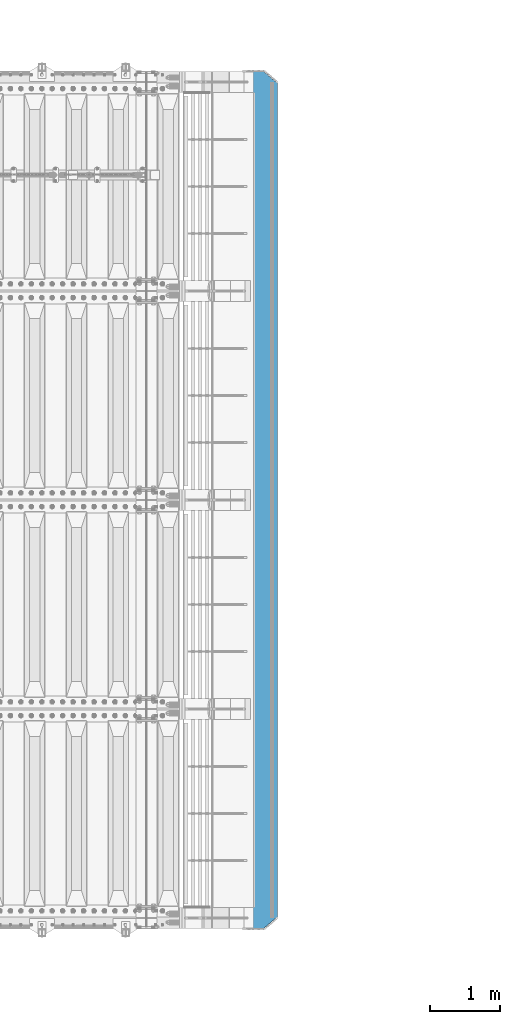
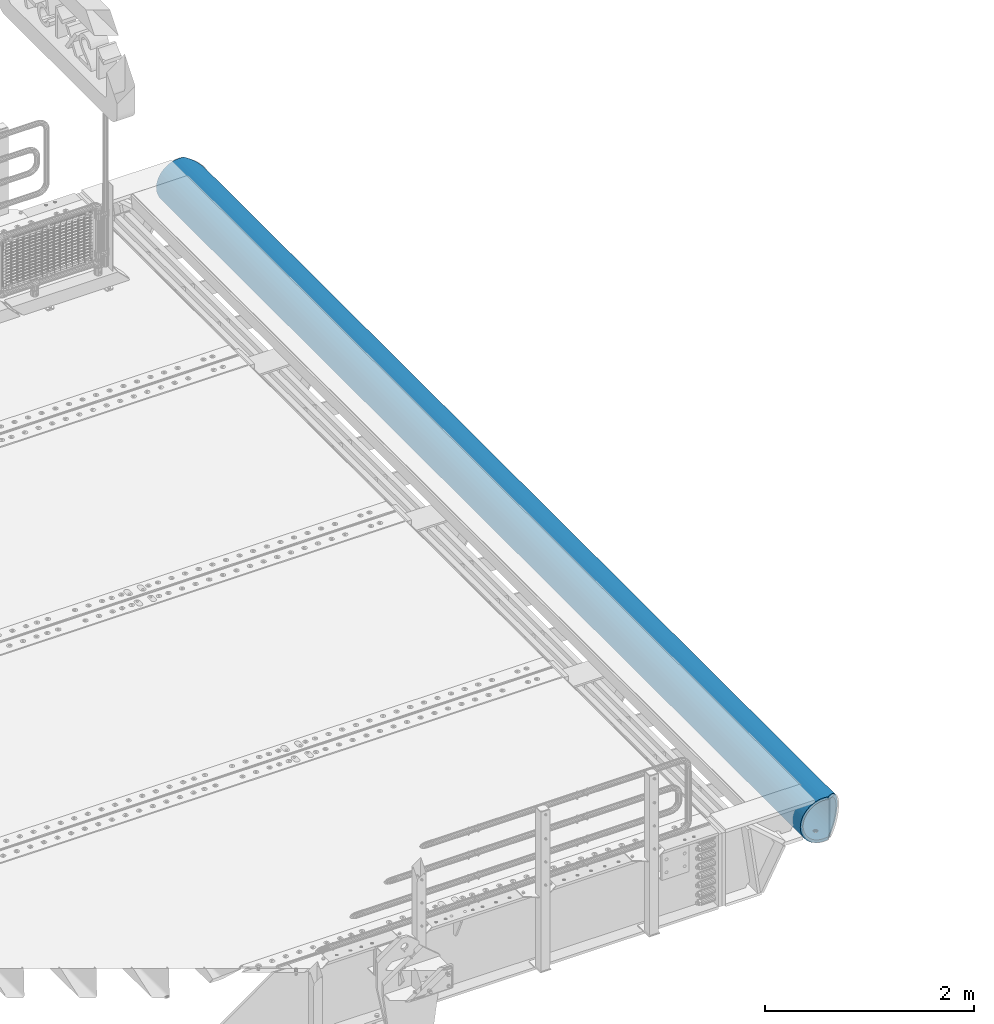
# One storey, part 129 of 240: 1 beam.
"""IFC2X3 building model written with IfcOpenShell, lengths in millimetres."""

from ifc_helpers import new_model, si_unit, frame, origin_with_axes, place, context, subcontext, project, spatial, faceted_brep, material, type_object, element, save


model = new_model("IFC2X3")

# Units and contexts
model_context = context("Model", 3, precision=1e-05, world=origin_with_axes())
body_context = subcontext(model_context, "Body", "Model", "MODEL_VIEW")
ifc_project = project(units=[si_unit("LENGTHUNIT", "METRE", prefix="MILLI"), si_unit("AREAUNIT", "SQUARE_METRE"), si_unit("VOLUMEUNIT", "CUBIC_METRE"), si_unit("MASSUNIT", "GRAM", prefix="KILO"), si_unit("TIMEUNIT", "SECOND"), si_unit("PLANEANGLEUNIT", "RADIAN"), si_unit("SOLIDANGLEUNIT", "STERADIAN"), si_unit("THERMODYNAMICTEMPERATUREUNIT", "DEGREE_CELSIUS"), si_unit("LUMINOUSINTENSITYUNIT", "LUMEN")], contexts=[model_context])

# Site, building, storey
site_placement = place(None, origin_with_axes())
site = spatial("IfcSite", under=ifc_project, at=site_placement, CompositionType="ELEMENT")
building_placement = place(site_placement, origin_with_axes())
building = spatial("IfcBuilding", under=site, at=building_placement, Name="Standard", CompositionType="ELEMENT")
storey_placement = place(building_placement, origin_with_axes())
storey = spatial("IfcBuildingStorey", under=building, at=storey_placement, Name="Undefined", CompositionType="ELEMENT", Elevation=0.0)

# Beam
ifc_material = material(Name="STEEL/S355N")
beam_type = type_object("IfcBeamType", PredefinedType="NOTDEFINED")
beam_placement = place(storey_placement, frame((57632.9988298906, 36150.0, -254.000000000001), z_axis=(0.0, 0.0, 1.0), x_axis=(0.0, -1.0, 0.0)))
element("IfcBeam", 1, at=beam_placement, inside=storey, type_object=beam_type, material=ifc_material, context=body_context, shape_type="Brep", body=[
    faceted_brep([(4626.90301168722, -9.56338969324133, -221.247344908115), (4626.90301168722, -9.56338969324133, -253.247344908114), (4625.0, 0.0, -254.0), (4625.0, 0.0, -222.0), (4632.32233047034, -17.6739734137809, -220.609028125964), (4632.32233047034, -17.6739734137809, -252.609028125964), (4640.43291419087, -23.0932921968997, -220.182518487905), (4640.43291419087, -23.0932921968997, -252.182518487906), (4650.0, -24.9963038841161, -220.032748220014), (4650.0, -24.9963038841161, -252.032748220015), (4659.56708580913, -23.0932921968997, -220.182518487905), (4659.56708580913, -23.0932921968997, -252.182518487906), (4667.67766952966, -17.6739734137809, -220.609028125964), (4667.67766952966, -17.6739734137809, -252.609028125964), (4673.09698831278, -9.56338969324133, -221.247344908115), (4673.09698831278, -9.56338969324133, -253.247344908114), (4675.0, 0.0, -222.0), (4675.0, 0.0, -254.0), (4673.09698831278, 9.57078192500921, -221.246763126854), (4673.09698831278, 9.57078192500921, -253.246763126854), (4667.67766952966, 17.6813656455488, -220.608446344703), (4667.67766952966, 17.6813656455488, -252.608446344703), (4659.56708580913, 23.1006844286676, -220.181936706645), (4659.56708580913, 23.1006844286676, -252.181936706646), (4650.0, 25.0036961158839, -220.032166438754), (4650.0, 25.0036961158839, -252.032166438755), (4640.43291419087, 23.1006844286676, -220.181936706645), (4640.43291419087, 23.1006844286676, -252.181936706646), (4632.32233047034, 17.6813656455488, -220.608446344703), (4632.32233047034, 17.6813656455488, -252.608446344703), (4626.90301168722, 9.57078192500921, -221.246763126854), (4626.90301168722, 9.57078192500921, -253.246763126854), (3126.90301168722, -9.56708580912527, -221.247054017484), (3126.90301168722, -9.56708580912527, -253.247054017484), (3125.0, 0.0, -254.0), (3125.0, 0.0, -222.0), (3132.32233047034, -17.6776695296649, -220.608737235334), (3132.32233047034, -17.6776695296649, -252.608737235333), (3140.43291419087, -23.0969883127837, -220.182227597276), (3140.43291419087, -23.0969883127837, -252.182227597276), (3150.0, -25.0, -220.032457329384), (3150.0, -25.0, -252.032457329385), (3159.56708580913, -23.0969883127837, -220.182227597276), (3159.56708580913, -23.0969883127837, -252.182227597276), (3167.67766952966, -17.6776695296649, -220.608737235334), (3167.67766952966, -17.6776695296649, -252.608737235333), (3173.09698831278, -9.56708580912527, -221.247054017484), (3173.09698831278, -9.56708580912527, -253.247054017484), (3175.0, 0.0, -222.0), (3175.0, 0.0, -254.0), (3173.09698831278, 9.56708580912527, -221.247054017484), (3173.09698831278, 9.56708580912527, -253.247054017485), (3167.67766952966, 17.6776695296649, -220.608737235333), (3167.67766952966, 17.6776695296649, -252.608737235334), (3159.56708580913, 23.0969883127837, -220.182227597276), (3159.56708580913, 23.0969883127837, -252.182227597275), (3150.0, 25.0, -220.032457329385), (3150.0, 25.0, -252.032457329385), (3140.43291419087, 23.0969883127837, -220.182227597276), (3140.43291419087, 23.0969883127837, -252.182227597275), (3132.32233047034, 17.6776695296649, -220.608737235333), (3132.32233047034, 17.6776695296649, -252.608737235334), (3126.90301168722, 9.56708580912527, -221.247054017484), (3126.90301168722, 9.56708580912527, -253.247054017485), (1626.90301168722, -9.56708580912527, -221.247054017486), (1626.90301168722, -9.56708580912527, -253.247054017484), (1625.0, 0.0, -254.0), (1625.0, 0.0, -222.0), (1632.32233047034, -17.6776695296649, -220.608737235335), (1632.32233047034, -17.6776695296649, -252.608737235335), (1640.43291419087, -23.0969883127837, -220.182227597277), (1640.43291419087, -23.0969883127837, -252.182227597276), (1650.0, -25.0, -220.032457329385), (1650.0, -25.0, -252.032457329385), (1659.56708580913, -23.0969883127837, -220.182227597277), (1659.56708580913, -23.0969883127837, -252.182227597276), (1667.67766952966, -17.6776695296649, -220.608737235335), (1667.67766952966, -17.6776695296649, -252.608737235335), (1673.09698831278, -9.56708580912527, -221.247054017486), (1673.09698831278, -9.56708580912527, -253.247054017484), (1675.0, 0.0, -222.0), (1675.0, 0.0, -254.0), (1673.09698831278, 9.56708580912527, -221.247054017484), (1673.09698831278, 9.56708580912527, -253.247054017484), (1667.67766952966, 17.6776695296649, -220.608737235334), (1667.67766952966, 17.6776695296649, -252.608737235334), (1659.56708580913, 23.0969883127837, -220.182227597276), (1659.56708580913, 23.0969883127837, -252.182227597276), (1650.0, 25.0, -220.032457329384), (1650.0, 25.0, -252.032457329384), (1640.43291419087, 23.0969883127837, -220.182227597276), (1640.43291419087, 23.0969883127837, -252.182227597276), (1632.32233047034, 17.6776695296649, -220.608737235334), (1632.32233047034, 17.6776695296649, -252.608737235334), (1626.90301168722, 9.56708580912527, -221.247054017484), (1626.90301168722, 9.56708580912527, -253.247054017484), (126.903011687216, -9.56708580912527, -221.247054017485), (126.903011687216, -9.56708580912527, -253.247054017485), (125.0, 0.0, -254.0), (125.0, 0.0, -222.0), (132.322330470335, -17.6776695296649, -220.608737235334), (132.322330470335, -17.6776695296649, -252.608737235334), (140.432914190875, -23.0969883127837, -220.182227597276), (140.432914190875, -23.0969883127837, -252.182227597276), (150.0, -25.0, -220.032457329384), (150.0, -25.0, -252.032457329385), (159.567085809125, -23.0969883127837, -220.182227597276), (159.567085809125, -23.0969883127837, -252.182227597276), (167.677669529665, -17.6776695296649, -220.608737235334), (167.677669529665, -17.6776695296649, -252.608737235334), (173.096988312784, -9.56708580912527, -221.247054017485), (173.096988312784, -9.56708580912527, -253.247054017485), (175.0, 0.0, -222.0), (175.0, 0.0, -254.0), (173.096988312784, 9.56708580912527, -221.247054017484), (173.096988312784, 9.56708580912527, -253.247054017484), (167.677669529665, 17.6776695296649, -220.608737235333), (167.677669529665, 17.6776695296649, -252.608737235334), (159.567085809125, 23.0969883127837, -220.182227597276), (159.567085809125, 23.0969883127837, -252.182227597276), (150.0, 25.0, -220.032457329384), (150.0, 25.0, -252.032457329385), (140.432914190875, 23.0969883127837, -220.182227597276), (140.432914190875, 23.0969883127837, -252.182227597276), (132.322330470335, 17.6776695296649, -220.608737235333), (132.322330470335, 17.6776695296649, -252.608737235334), (126.903011687216, 9.56708580912527, -221.247054017484), (126.903011687216, 9.56708580912527, -253.247054017484), (0.0, -34.7284512389306, -219.266811612121), (0.0, -68.6017727512371, -211.134546617524), (12300.0, -68.6017727512371, -211.134546617524), (12300.0, -34.7284512389306, -219.266811612121), (0.0, -100.785890942178, -197.803448369818), (12300.0, -100.785890942178, -197.803448369818), (0.0, -130.488326008926, -179.601772751238), (12300.0, -130.488326008926, -179.601772751238), (0.0, -156.977705423415, -156.977705423414), (12300.0, -156.977705423415, -156.977705423414), (0.0, -179.601772751237, -130.488326008929), (12300.0, -179.601772751237, -130.488326008929), (0.0, -197.803448369821, -100.785890942179), (12300.0, -197.803448369821, -100.785890942179), (0.0, -211.134546617526, -68.6017727512383), (12300.0, -211.134546617526, -68.6017727512383), (0.0, -219.26681161212, -34.7284512389313), (12300.0, -219.26681161212, -34.7284512389313), (0.0, -222.0, 0.0), (12300.0, -222.0, 0.0), (0.0, -219.26681161212, 34.7284512389313), (12300.0, -219.26681161212, 34.7284512389313), (0.0, -211.134546617526, 68.6017727512384), (12300.0, -211.134546617526, 68.6017727512384), (0.0, -197.803448369821, 100.785890942179), (12300.0, -197.803448369821, 100.785890942179), (0.0, -179.601772751237, 130.488326008929), (12300.0, -179.601772751237, 130.488326008929), (0.0, -156.977705423415, 156.977705423414), (12300.0, -156.977705423415, 156.977705423414), (0.0, -130.488326008926, 179.601772751238), (12300.0, -130.488326008926, 179.601772751238), (0.0, -100.785890942178, 197.803448369818), (12300.0, -100.785890942178, 197.803448369818), (0.0, -68.6017727512371, 211.134546617524), (12300.0, -68.6017727512371, 211.134546617524), (0.0, -34.7284512389306, 219.266811612121), (12300.0, -34.7284512389306, 219.266811612121), (0.0, 0.0, 222.0), (12300.0, 0.0, 222.0), (0.0, 34.7284512389306, 219.266811612121), (12300.0, 34.7284512389306, 219.266811612121), (12287.5916350976, 68.6017727512371, 211.134546617524), (12300.0, 54.0036961158839, 214.639234741096), (0.0, 54.0, 214.640122100011), (12.4115067427192, 68.6017727512371, 211.134546617524), (12260.2351351591, 100.785890942178, 197.803448369818), (39.7680069938215, 100.785890942178, 197.803448369818), (12234.9880658358, 130.488326008926, 179.601772751238), (65.0150766056468, 130.488326008926, 179.601772751238), (12212.4720937646, 156.977705423415, 156.977705423414), (87.5310489341209, 156.977705423415, 156.977705423414), (12193.2416369042, 179.601772751237, 130.488326008929), (106.761506014307, 179.601772751237, 130.488326008929), (12177.7702129247, 197.803448369821, 100.785890942179), (122.232930170649, 197.803448369821, 100.785890942179), (12166.4387796311, 211.134546617526, 68.6017727512383), (133.564363593716, 211.134546617526, 68.6017727512383), (12159.5263545181, 219.26681161212, 34.7284512389312), (140.476788785745, 219.26681161212, 34.7284512389312), (12157.2031444329, 222.0, -2.8421709430404e-14), (142.799998897506, 222.0, -2.8421709430404e-14), (12159.5263545181, 219.26681161212, -34.7284512389313), (140.476788785745, 219.26681161212, -34.7284512389313), (12166.4387796311, 211.134546617526, -68.6017727512383), (133.564363593716, 211.134546617526, -68.6017727512383), (12177.7702129247, 197.803448369821, -100.785890942179), (122.232930170649, 197.803448369821, -100.785890942179), (12193.2416369042, 179.601772751237, -130.488326008929), (106.761506014307, 179.601772751237, -130.488326008929), (12212.4720937646, 156.977705423415, -156.977705423414), (87.5310489341209, 156.977705423415, -156.977705423414), (12234.9880658358, 130.488326008926, -179.601772751238), (65.0150766056468, 130.488326008926, -179.601772751238), (12260.2351351591, 100.785890942178, -197.803448369818), (39.7680069938215, 100.785890942178, -197.803448369818), (12287.5916350976, 68.6017727512371, -211.134546617524), (12.4115067427192, 68.6017727512371, -211.134546617524), (0.0, 34.7284512389306, -219.266811612121), (12300.0, 34.7284512389306, -219.266811612121), (12300.0, 54.0036961158839, -214.639234741096), (0.0, 54.0, -214.640122100011), (12140.5700428833, 241.568355138967, -78.4903165712366), (12153.5348359309, 226.315657143845, -115.313586933845), (146.468307441457, 226.315657143845, -115.313586933845), (159.433100637223, 241.568355138967, -78.4903165712366), (12171.2363750786, 205.490316571239, -149.297454082288), (128.766768091402, 205.490316571239, -149.297454082288), (12193.2387896847, 179.605122421381, -179.605122421383), (106.764353233899, 179.605122421381, -179.605122421383), (12219.0003072796, 149.297454082291, -205.490316571237), (81.0028353445668, 149.297454082291, -205.490316571237), (12247.8865938026, 115.313586933844, -226.315657143845), (52.116548491409, 115.313586933844, -226.315657143845), (12279.1863730115, 78.4903165712385, -241.568355138969), (20.8167689248367, 78.4903165712385, -241.568355138969), (12300.0, 54.0036961158839, -247.447072591956), (12300.0, 39.7343541202208, -250.872838511165), (0.0, 39.7343541202208, -250.872838511165), (0.0, 54.0, -247.447959950871), (0.0, 0.0, -222.0), (0.0, 0.0, -254.0), (0.0, -39.7343541202208, -250.872838511165), (0.0, -78.4903165712385, -241.568355138969), (0.0, -115.313586933844, -226.315657143845), (0.0, -149.297454082291, -205.490316571237), (0.0, -179.605122421381, -179.605122421383), (0.0, -205.490316571239, -149.297454082288), (0.0, -226.315657143845, -115.313586933845), (0.0, -241.568355138967, -78.4903165712367), (0.0, -250.872838511168, -39.7343541202187), (0.0, -254.0, 0.0), (0.0, -250.872838511168, 39.7343541202187), (0.0, -241.568355138967, 78.4903165712366), (0.0, -226.315657143845, 115.313586933845), (0.0, -205.490316571239, 149.297454082288), (0.0, -179.605122421381, 179.605122421383), (0.0, -149.297454082291, 205.490316571237), (0.0, -115.313586933844, 226.315657143845), (0.0, -78.4903165712385, 241.568355138969), (0.0, -39.7343541202208, 250.872838511165), (0.0, 0.0, 254.0), (0.0, 39.7343541202208, 250.872838511165), (0.0, 54.0, 247.447959950871), (12300.0, -39.7343541202208, -250.872838511165), (12300.0, -78.4903165712385, -241.568355138969), (12300.0, -115.313586933844, -226.315657143845), (12300.0, -149.297454082291, -205.490316571237), (12300.0, -179.605122421381, -179.605122421383), (12300.0, -205.490316571239, -149.297454082288), (12300.0, -226.315657143845, -115.313586933845), (12300.0, -241.568355138967, -78.4903165712367), (12300.0, -250.872838511168, -39.7343541202187), (12300.0, -254.0, 0.0), (12300.0, -250.872838511168, 39.7343541202187), (12300.0, -241.568355138967, 78.4903165712366), (12300.0, -226.315657143845, 115.313586933845), (12300.0, -205.490316571239, 149.297454082288), (12300.0, -179.605122421381, 179.605122421383), (12300.0, -149.297454082291, 205.490316571237), (12300.0, -115.313586933844, 226.315657143845), (12300.0, -78.4903165712385, 241.568355138969), (12300.0, -39.7343541202208, 250.872838511165), (12300.0, 0.0, 254.0), (12300.0, 39.7343541202208, 250.872838511165), (12300.0, 54.0036961158839, 247.447072591956), (12279.1863730115, 78.4903165712385, 241.568355138969), (20.8167689248367, 78.4903165712385, 241.568355138969), (12247.8865938026, 115.313586933844, 226.315657143845), (52.116548491409, 115.313586933844, 226.315657143845), (12219.0003072796, 149.297454082291, 205.490316571237), (81.0028353445668, 149.297454082291, 205.490316571237), (12193.2387896847, 179.605122421381, 179.605122421383), (106.764353233899, 179.605122421381, 179.605122421383), (12171.2363750786, 205.490316571239, 149.297454082288), (128.766768091402, 205.490316571239, 149.297454082288), (12153.5348359309, 226.315657143845, 115.313586933845), (146.468307441457, 226.315657143845, 115.313586933845), (12140.5700428833, 241.568355138967, 78.4903165712367), (159.433100637223, 241.568355138967, 78.4903165712367), (12129.9999998327, 254.003700142486, 0.0), (12132.6612321683, 250.872838511168, -39.7343541202186), (167.341911442534, 250.872838511168, -39.7343541202186), (170.000001295222, 254.000003067893, 5.6843418860808e-14), (12132.6612321683, 250.872838511168, 39.7343541202187), (167.341911442534, 250.872838511168, 39.7343541202187), (12300.0, 0.0, -254.0), (12300.0, 0.0, -222.0), (12126.9030116872, -9.56338969324861, -221.247344908115), (12126.9030116872, -9.56338969324861, -253.247344908113), (12125.0, 0.0, -254.0), (12125.0, 0.0, -222.0), (12132.3223304703, -17.6739734137882, -220.609028125964), (12132.3223304703, -17.6739734137882, -252.609028125963), (12140.4329141909, -23.093292196907, -220.182518487906), (12140.4329141909, -23.093292196907, -252.182518487905), (12150.0, -24.9963038841233, -220.032748220015), (12150.0, -24.9963038841233, -252.032748220014), (12159.5670858091, -23.093292196907, -220.182518487906), (12159.5670858091, -23.093292196907, -252.182518487905), (12167.6776695297, -17.6739734137882, -220.609028125964), (12167.6776695297, -17.6739734137882, -252.609028125963), (12173.0969883128, -9.56338969324861, -221.247344908115), (12173.0969883128, -9.56338969324861, -253.247344908113), (12175.0, 0.0, -222.0), (12175.0, 0.0, -254.0), (12173.0969883128, 9.57078192500194, -221.246763126854), (12173.0969883128, 9.57078192500194, -253.246763126856), (12167.6776695297, 17.6813656455415, -220.608446344704), (12167.6776695297, 17.6813656455415, -252.608446344706), (12159.5670858091, 23.1006844286603, -220.181936706646), (12159.5670858091, 23.1006844286603, -252.181936706648), (12150.0, 25.0036961158767, -220.032166438754), (12150.0, 25.0036961158767, -252.032166438757), (12140.4329141909, 23.1006844286603, -220.181936706646), (12140.4329141909, 23.1006844286603, -252.181936706648), (12132.3223304703, 17.6813656455415, -220.608446344704), (12132.3223304703, 17.6813656455415, -252.608446344706), (12126.9030116872, 9.57078192500194, -221.246763126854), (12126.9030116872, 9.57078192500194, -253.246763126856), (10626.9030116872, -9.56338969324861, -221.247344908114), (10626.9030116872, -9.56338969324861, -253.247344908111), (10625.0, 0.0, -254.0), (10625.0, 0.0, -222.0), (10632.3223304703, -17.6739734137882, -220.609028125963), (10632.3223304703, -17.6739734137882, -252.609028125961), (10640.4329141909, -23.093292196907, -220.182518487905), (10640.4329141909, -23.093292196907, -252.182518487903), (10650.0, -24.9963038841233, -220.032748220014), (10650.0, -24.9963038841233, -252.032748220012), (10659.5670858091, -23.093292196907, -220.182518487905), (10659.5670858091, -23.093292196907, -252.182518487903), (10667.6776695297, -17.6739734137882, -220.609028125963), (10667.6776695297, -17.6739734137882, -252.609028125961), (10673.0969883128, -9.56338969324861, -221.247344908114), (10673.0969883128, -9.56338969324861, -253.247344908111), (10675.0, 0.0, -222.0), (10675.0, 0.0, -254.0), (10673.0969883128, 9.57078192500194, -221.246763126852), (10673.0969883128, 9.57078192500194, -253.246763126853), (10667.6776695297, 17.6813656455415, -220.608446344702), (10667.6776695297, 17.6813656455415, -252.608446344703), (10659.5670858091, 23.1006844286603, -220.181936706644), (10659.5670858091, 23.1006844286603, -252.181936706645), (10650.0, 25.0036961158767, -220.032166438753), (10650.0, 25.0036961158767, -252.032166438754), (10640.4329141909, 23.1006844286603, -220.181936706644), (10640.4329141909, 23.1006844286603, -252.181936706645), (10632.3223304703, 17.6813656455415, -220.608446344702), (10632.3223304703, 17.6813656455415, -252.608446344703), (10626.9030116872, 9.57078192500194, -221.246763126852), (10626.9030116872, 9.57078192500194, -253.246763126853), (9132.32233047034, 17.6813656455415, -252.608446344704), (9126.90301168722, 9.57078192500194, -253.246763126854), (9125.0, 0.0, -254.0), (7675.0, 0.0, -254.0), (7673.09698831278, 9.57078192500194, -253.246763126854), (7667.67766952966, 17.6813656455415, -252.608446344704), (7659.56708580913, 23.1006844286603, -252.181936706646), (7650.0, 25.0036961158767, -252.032166438755), (7640.43291419087, 23.1006844286603, -252.181936706646), (7632.32233047034, 17.6813656455415, -252.608446344704), (7626.90301168722, 9.57078192500194, -253.246763126854), (7625.0, 0.0, -254.0), (6175.0, 0.0, -254.0), (6173.09698831278, 9.57078192500194, -253.246763126855), (6167.67766952966, 17.6813656455415, -252.608446344705), (6159.56708580913, 23.1006844286603, -252.181936706647), (6150.0, 25.0036961158767, -252.032166438756), (6140.43291419087, 23.1006844286603, -252.181936706647), (6132.32233047034, 17.6813656455415, -252.608446344705), (6126.90301168722, 9.57078192500194, -253.246763126855), (6125.0, 0.0, -254.0), (9175.0, 0.0, -254.0), (9173.09698831278, 9.57078192500194, -253.246763126854), (9167.67766952966, 17.6813656455415, -252.608446344704), (9159.56708580913, 23.1006844286603, -252.181936706646), (9150.0, 25.0036961158767, -252.032166438755), (9140.43291419087, 23.1006844286603, -252.181936706646), (7667.67766952966, 17.6813656455415, -220.608446344702), (7673.09698831278, 9.57078192500194, -221.246763126853), (7659.56708580913, 23.1006844286603, -220.181936706645), (7650.0, 25.0036961158767, -220.032166438754), (7640.43291419087, 23.1006844286603, -220.181936706645), (7632.32233047034, 17.6813656455415, -220.608446344702), (7626.90301168722, 9.57078192500194, -221.246763126853), (7625.0, 0.0, -222.0), (7626.90301168722, -9.56338969324861, -221.247344908116), (7626.90301168722, -9.56338969324861, -253.247344908112), (7632.32233047034, -17.6739734137882, -220.609028125965), (7632.32233047034, -17.6739734137882, -252.609028125961), (7640.43291419087, -23.093292196907, -220.182518487907), (7640.43291419087, -23.093292196907, -252.182518487903), (7650.0, -24.9963038841233, -220.032748220015), (7650.0, -24.9963038841233, -252.032748220012), (7659.56708580913, -23.093292196907, -220.182518487907), (7659.56708580913, -23.093292196907, -252.182518487903), (7667.67766952966, -17.6739734137882, -220.609028125965), (7667.67766952966, -17.6739734137882, -252.609028125961), (7673.09698831278, -9.56338969324861, -221.247344908116), (7673.09698831278, -9.56338969324861, -253.247344908112), (7675.0, 0.0, -222.0), (9167.67766952966, 17.6813656455415, -220.608446344703), (9173.09698831278, 9.57078192500194, -221.246763126854), (9175.0, 0.0, -222.0), (6125.0, 0.0, -222.0), (6126.90301168722, 9.57078192500194, -221.246763126856), (6132.32233047034, 17.6813656455415, -220.608446344706), (6140.43291419087, 23.1006844286603, -220.181936706647), (6150.0, 25.0036961158767, -220.032166438755), (6159.56708580913, 23.1006844286603, -220.181936706647), (6167.67766952966, 17.6813656455415, -220.608446344706), (6173.09698831278, 9.57078192500194, -221.246763126856), (6175.0, 0.0, -222.0), (9125.0, 0.0, -222.0), (9126.90301168722, 9.57078192500194, -221.246763126854), (9132.32233047034, 17.6813656455415, -220.608446344703), (9140.43291419087, 23.1006844286603, -220.181936706645), (9150.0, 25.0036961158767, -220.032166438754), (9159.56708580913, 23.1006844286603, -220.181936706645), (6173.09698831278, -9.56338969324861, -221.247344908115), (6167.67766952966, -17.6739734137882, -220.609028125964), (6159.56708580913, -23.093292196907, -220.182518487906), (6150.0, -24.9963038841233, -220.032748220015), (6140.43291419087, -23.093292196907, -220.182518487906), (6132.32233047034, -17.6739734137882, -220.609028125964), (6126.90301168722, -9.56338969324861, -221.247344908115), (9173.09698831278, -9.56338969324861, -221.247344908112), (9167.67766952966, -17.6739734137882, -220.609028125962), (9159.56708580913, -23.093292196907, -220.182518487903), (9150.0, -24.9963038841233, -220.032748220012), (9140.43291419087, -23.093292196907, -220.182518487903), (9132.32233047034, -17.6739734137882, -220.609028125962), (9126.90301168722, -9.56338969324861, -221.247344908112), (9132.32233047034, -17.6739734137882, -252.609028125962), (9126.90301168722, -9.56338969324861, -253.247344908113), (9140.43291419087, -23.093292196907, -252.182518487905), (9150.0, -24.9963038841233, -252.032748220014), (9159.56708580913, -23.093292196907, -252.182518487905), (9167.67766952966, -17.6739734137882, -252.609028125962), (9173.09698831278, -9.56338969324861, -253.247344908113), (6126.90301168722, -9.56338969324861, -253.247344908114), (6132.32233047034, -17.6739734137882, -252.609028125964), (6140.43291419087, -23.093292196907, -252.182518487905), (6150.0, -24.9963038841233, -252.032748220014), (6159.56708580913, -23.093292196907, -252.182518487905), (6167.67766952966, -17.6739734137882, -252.609028125964), (6173.09698831278, -9.56338969324861, -253.247344908114)], [[[0, 1, 2, 3]], [[4, 5, 1, 0]], [[6, 7, 5, 4]], [[8, 9, 7, 6]], [[10, 11, 9, 8]], [[12, 13, 11, 10]], [[14, 15, 13, 12]], [[16, 17, 15, 14]], [[18, 19, 17, 16]], [[20, 21, 19, 18]], [[22, 23, 21, 20]], [[24, 25, 23, 22]], [[26, 27, 25, 24]], [[28, 29, 27, 26]], [[30, 31, 29, 28]], [[3, 2, 31, 30]], [[32, 33, 34, 35]], [[36, 37, 33, 32]], [[38, 39, 37, 36]], [[40, 41, 39, 38]], [[42, 43, 41, 40]], [[44, 45, 43, 42]], [[46, 47, 45, 44]], [[48, 49, 47, 46]], [[50, 51, 49, 48]], [[52, 53, 51, 50]], [[54, 55, 53, 52]], [[56, 57, 55, 54]], [[58, 59, 57, 56]], [[60, 61, 59, 58]], [[62, 63, 61, 60]], [[35, 34, 63, 62]], [[64, 65, 66, 67]], [[68, 69, 65, 64]], [[70, 71, 69, 68]], [[72, 73, 71, 70]], [[74, 75, 73, 72]], [[76, 77, 75, 74]], [[78, 79, 77, 76]], [[80, 81, 79, 78]], [[82, 83, 81, 80]], [[84, 85, 83, 82]], [[86, 87, 85, 84]], [[88, 89, 87, 86]], [[90, 91, 89, 88]], [[92, 93, 91, 90]], [[94, 95, 93, 92]], [[67, 66, 95, 94]], [[96, 97, 98, 99]], [[100, 101, 97, 96]], [[102, 103, 101, 100]], [[104, 105, 103, 102]], [[106, 107, 105, 104]], [[108, 109, 107, 106]], [[110, 111, 109, 108]], [[112, 113, 111, 110]], [[114, 115, 113, 112]], [[116, 117, 115, 114]], [[118, 119, 117, 116]], [[120, 121, 119, 118]], [[122, 123, 121, 120]], [[124, 125, 123, 122]], [[126, 127, 125, 124]], [[99, 98, 127, 126]], [[128, 129, 130, 131]], [[129, 132, 133, 130]], [[132, 134, 135, 133]], [[134, 136, 137, 135]], [[136, 138, 139, 137]], [[138, 140, 141, 139]], [[140, 142, 143, 141]], [[142, 144, 145, 143]], [[144, 146, 147, 145]], [[146, 148, 149, 147]], [[148, 150, 151, 149]], [[150, 152, 153, 151]], [[152, 154, 155, 153]], [[154, 156, 157, 155]], [[156, 158, 159, 157]], [[158, 160, 161, 159]], [[160, 162, 163, 161]], [[162, 164, 165, 163]], [[164, 166, 167, 165]], [[166, 168, 169, 167]], [[170, 171, 169, 168, 172, 173]], [[174, 170, 173, 175]], [[176, 174, 175, 177]], [[178, 176, 177, 179]], [[180, 178, 179, 181]], [[182, 180, 181, 183]], [[184, 182, 183, 185]], [[186, 184, 185, 187]], [[188, 186, 187, 189]], [[190, 188, 189, 191]], [[192, 190, 191, 193]], [[194, 192, 193, 195]], [[196, 194, 195, 197]], [[198, 196, 197, 199]], [[200, 198, 199, 201]], [[202, 200, 201, 203]], [[204, 202, 203, 205]], [[206, 207, 208, 204, 205, 209]], [[210, 211, 212, 213]], [[211, 214, 215, 212]], [[214, 216, 217, 215]], [[216, 218, 219, 217]], [[218, 220, 221, 219]], [[220, 222, 223, 221]], [[222, 224, 225, 226, 227, 223]], [[168, 166, 164, 162, 160, 158, 156, 154, 152, 150, 148, 146, 144, 142, 140, 138, 136, 134, 132, 129, 128, 228, 206, 209, 227, 226, 229, 230, 231, 232, 233, 234, 235, 236, 237, 238, 239, 240, 241, 242, 243, 244, 245, 246, 247, 248, 249, 250, 251, 172]], [[231, 230, 252, 253]], [[232, 231, 253, 254]], [[233, 232, 254, 255]], [[234, 233, 255, 256]], [[235, 234, 256, 257]], [[236, 235, 257, 258]], [[237, 236, 258, 259]], [[238, 237, 259, 260]], [[239, 238, 260, 261]], [[240, 239, 261, 262]], [[241, 240, 262, 263]], [[242, 241, 263, 264]], [[243, 242, 264, 265]], [[244, 243, 265, 266]], [[245, 244, 266, 267]], [[246, 245, 267, 268]], [[247, 246, 268, 269]], [[248, 247, 269, 270]], [[249, 248, 270, 271]], [[250, 249, 271, 272]], [[250, 272, 273, 274, 275, 251]], [[274, 276, 277, 275]], [[276, 278, 279, 277]], [[278, 280, 281, 279]], [[280, 282, 283, 281]], [[282, 284, 285, 283]], [[284, 286, 287, 285]], [[288, 289, 290, 291]], [[292, 288, 291, 293]], [[286, 292, 293, 287]], [[291, 290, 213, 212, 215, 217, 219, 221, 223, 227, 209, 205, 203, 201, 199, 197, 195, 193, 191, 189, 187, 185, 183, 181, 179, 177, 175, 173, 172, 251, 275, 277, 279, 281, 283, 285, 287, 293]], [[289, 210, 213, 290]], [[288, 292, 286, 284, 282, 280, 278, 276, 274, 273, 171, 170, 174, 176, 178, 180, 182, 184, 186, 188, 190, 192, 194, 196, 198, 200, 202, 204, 208, 224, 222, 220, 218, 216, 214, 211, 210, 289]], [[272, 271, 270, 269, 268, 267, 266, 265, 264, 263, 262, 261, 260, 259, 258, 257, 256, 255, 254, 253, 252, 294, 225, 224, 208, 207, 295, 131, 130, 133, 135, 137, 139, 141, 143, 145, 147, 149, 151, 153, 155, 157, 159, 161, 163, 165, 167, 169, 171, 273]], [[296, 297, 298, 299]], [[300, 301, 297, 296]], [[302, 303, 301, 300]], [[304, 305, 303, 302]], [[306, 307, 305, 304]], [[308, 309, 307, 306]], [[310, 311, 309, 308]], [[312, 313, 311, 310]], [[314, 315, 313, 312]], [[316, 317, 315, 314]], [[318, 319, 317, 316]], [[320, 321, 319, 318]], [[322, 323, 321, 320]], [[324, 325, 323, 322]], [[326, 327, 325, 324]], [[299, 298, 327, 326]], [[328, 329, 330, 331]], [[332, 333, 329, 328]], [[334, 335, 333, 332]], [[336, 337, 335, 334]], [[338, 339, 337, 336]], [[340, 341, 339, 338]], [[342, 343, 341, 340]], [[344, 345, 343, 342]], [[346, 347, 345, 344]], [[348, 349, 347, 346]], [[350, 351, 349, 348]], [[352, 353, 351, 350]], [[354, 355, 353, 352]], [[356, 357, 355, 354]], [[358, 359, 357, 356]], [[331, 330, 359, 358]], [[360, 361, 362, 363, 364, 365, 366, 367, 368, 369, 370, 371, 372, 373, 374, 375, 376, 377, 378, 379, 380, 17, 19, 21, 23, 25, 27, 29, 31, 2, 49, 51, 53, 55, 57, 59, 61, 63, 34, 81, 83, 85, 87, 89, 91, 93, 95, 66, 113, 115, 117, 119, 121, 123, 125, 127, 98, 229, 226, 225, 294, 313, 315, 317, 319, 321, 323, 325, 327, 298, 345, 347, 349, 351, 353, 355, 357, 359, 330, 381, 382, 383, 384, 385, 386]], [[387, 365, 364, 388]], [[389, 366, 365, 387]], [[390, 367, 366, 389]], [[391, 368, 367, 390]], [[392, 369, 368, 391]], [[393, 370, 369, 392]], [[394, 371, 370, 393]], [[395, 396, 371, 394]], [[397, 398, 396, 395]], [[399, 400, 398, 397]], [[401, 402, 400, 399]], [[403, 404, 402, 401]], [[405, 406, 404, 403]], [[407, 408, 406, 405]], [[409, 363, 408, 407]], [[388, 364, 363, 409]], [[410, 411, 412, 331, 358, 356, 354, 352, 350, 348, 346, 344, 299, 326, 324, 322, 320, 318, 316, 314, 312, 295, 207, 206, 228, 99, 126, 124, 122, 120, 118, 116, 114, 112, 67, 94, 92, 90, 88, 86, 84, 82, 80, 35, 62, 60, 58, 56, 54, 52, 50, 48, 3, 30, 28, 26, 24, 22, 20, 18, 16, 413, 414, 415, 416, 417, 418, 419, 420, 421, 394, 393, 392, 391, 390, 389, 387, 388, 409, 422, 423, 424, 425, 426, 427]], [[409, 407, 405, 403, 401, 399, 397, 395, 394, 421, 428, 429, 430, 431, 432, 433, 434, 413, 16, 14, 12, 10, 8, 6, 4, 0, 3, 48, 46, 44, 42, 40, 38, 36, 32, 35, 80, 78, 76, 74, 72, 70, 68, 64, 67, 112, 110, 108, 106, 104, 102, 100, 96, 99, 228, 128, 131, 295, 312, 310, 308, 306, 304, 302, 300, 296, 299, 344, 342, 340, 338, 336, 334, 332, 328, 331, 412, 435, 436, 437, 438, 439, 440, 441, 422]], [[440, 442, 443, 441]], [[439, 444, 442, 440]], [[438, 445, 444, 439]], [[437, 446, 445, 438]], [[436, 447, 446, 437]], [[435, 448, 447, 436]], [[412, 381, 448, 435]], [[411, 382, 381, 412]], [[410, 383, 382, 411]], [[427, 384, 383, 410]], [[426, 385, 384, 427]], [[425, 386, 385, 426]], [[424, 360, 386, 425]], [[423, 361, 360, 424]], [[422, 362, 361, 423]], [[441, 443, 362, 422]], [[442, 444, 445, 446, 447, 448, 381, 330, 329, 333, 335, 337, 339, 341, 343, 345, 298, 297, 301, 303, 305, 307, 309, 311, 313, 294, 252, 230, 229, 98, 97, 101, 103, 105, 107, 109, 111, 113, 66, 65, 69, 71, 73, 75, 77, 79, 81, 34, 33, 37, 39, 41, 43, 45, 47, 49, 2, 1, 5, 7, 9, 11, 13, 15, 17, 380, 449, 450, 451, 452, 453, 454, 455, 372, 371, 396, 398, 400, 402, 404, 406, 408, 363, 362, 443]], [[432, 451, 450, 433]], [[431, 452, 451, 432]], [[430, 453, 452, 431]], [[429, 454, 453, 430]], [[428, 455, 454, 429]], [[421, 372, 455, 428]], [[420, 373, 372, 421]], [[419, 374, 373, 420]], [[418, 375, 374, 419]], [[417, 376, 375, 418]], [[416, 377, 376, 417]], [[415, 378, 377, 416]], [[414, 379, 378, 415]], [[413, 380, 379, 414]], [[434, 449, 380, 413]], [[433, 450, 449, 434]]]),
])

save(model, "model.ifc")
